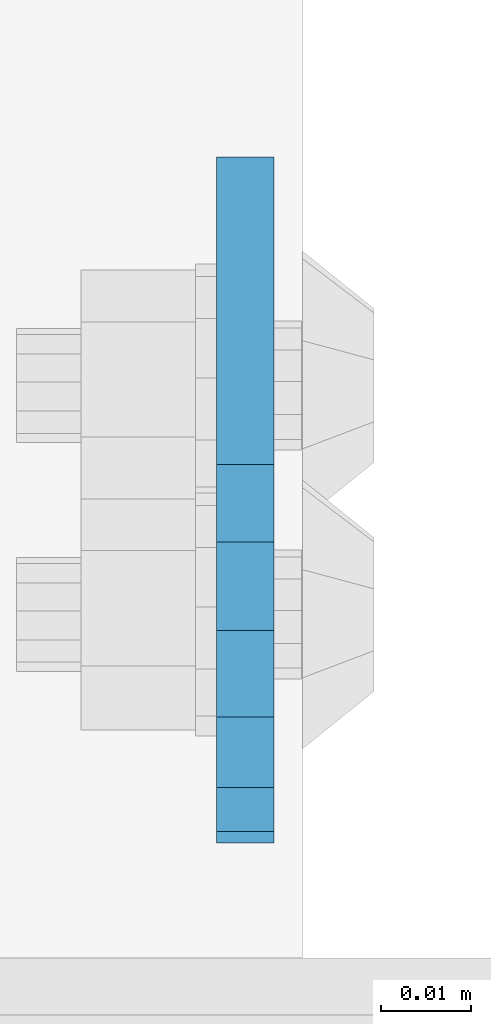
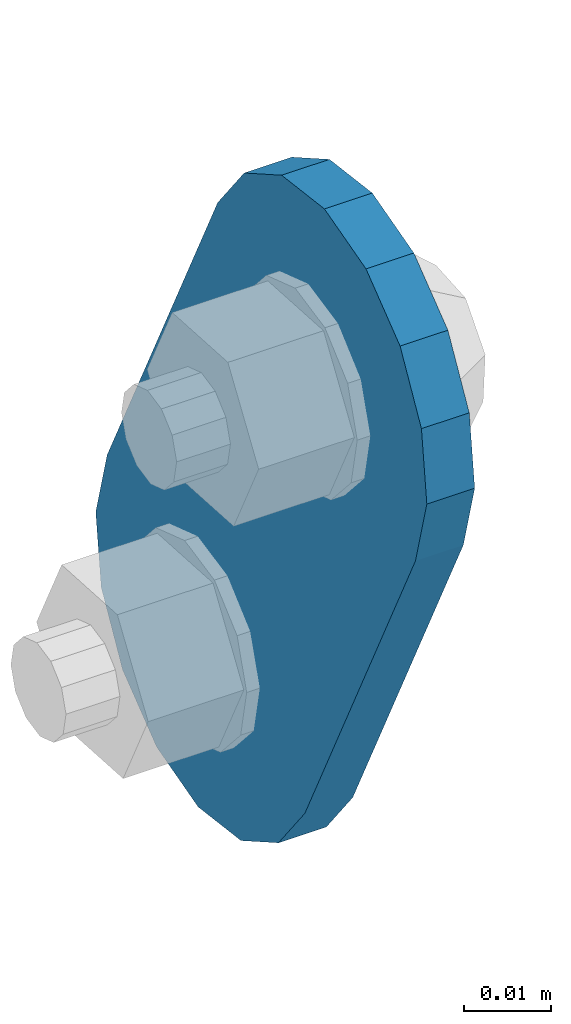
# One storey, part 1835 of 1876: 1 plate, 1 element without a shape of its own.
"""IFC2X3 building model written with IfcOpenShell, lengths in millimetres."""

from ifc_helpers import new_model, si_unit, frame, origin_with_axes, place, context, subcontext, project, spatial, faceted_brep, material, type_object, element, aggregate, save


model = new_model("IFC2X3")

# Units and contexts
model_context = context("Model", 3, precision=1e-05, world=origin_with_axes())
body_context = subcontext(model_context, "Body", "Model", "MODEL_VIEW")
ifc_project = project(units=[si_unit("LENGTHUNIT", "METRE", prefix="MILLI"), si_unit("AREAUNIT", "SQUARE_METRE"), si_unit("VOLUMEUNIT", "CUBIC_METRE"), si_unit("MASSUNIT", "GRAM", prefix="KILO"), si_unit("TIMEUNIT", "SECOND"), si_unit("PLANEANGLEUNIT", "RADIAN"), si_unit("SOLIDANGLEUNIT", "STERADIAN"), si_unit("THERMODYNAMICTEMPERATUREUNIT", "DEGREE_CELSIUS"), si_unit("LUMINOUSINTENSITYUNIT", "LUMEN")], contexts=[model_context])

# Site, building, storey
site_placement = place(None, origin_with_axes())
site = spatial("IfcSite", under=ifc_project, at=site_placement, CompositionType="ELEMENT")
building_placement = place(site_placement, origin_with_axes())
building = spatial("IfcBuilding", under=site, at=building_placement, Name="Undefined", CompositionType="ELEMENT")
storey_placement = place(building_placement, origin_with_axes())
storey = spatial("IfcBuildingStorey", under=building, at=storey_placement, Name="Undefined", CompositionType="ELEMENT", Elevation=0.0)

# Assembly, plate
assembly_placement = place(storey_placement, origin_with_axes())
assembly = element("IfcElementAssembly", 1, at=assembly_placement, inside=storey, Name="PLATE", AssemblyPlace="NOTDEFINED", PredefinedType="RIGID_FRAME")
ifc_material = material(Name="STEEL/A36")
plate_type = type_object("IfcPlateType", PredefinedType="NOTDEFINED")
plate_placement = place(assembly_placement, frame((7905.73879597858, 14070.2592249372, 7895.37767748094), z_axis=(0.0, -0.894427191199917, -0.447213595099956), x_axis=(0.0, 0.447213595099955, -0.894427191199917)))
plate = element("IfcPlate", 2, at=plate_placement, type_object=plate_type, material=ifc_material, Name="PLATE", context=body_context, shape_type="Brep", body=[
    faceted_brep([(-8.59611645864788e-07, -3.17499999999654, 25.3999987589127), (1.93345873884391, -3.17499999999382, 35.1201580589886), (1.93345873884391, 3.17500000000564, 35.1201580589886), (-8.59611645864788e-07, 3.17500000000382, 25.3999987589132), (7.43948648259902, -3.17499999999109, 43.3605112870105), (7.43948648259902, 3.17500000000928, 43.3605112870105), (15.6798395242777, -3.17499999998654, 48.8665393096448), (15.6798395242777, 3.17500000001382, 48.8665393096448), (25.3999987589095, -3.17499999998199, 50.7999992370592), (25.3999987589095, 3.17500000001837, 50.7999992370592), (82.196130752618, -3.17499999998381, 50.7999992370605), (82.196130752618, 3.17500000001655, 50.7999992370642), (91.9162897887145, -3.17499999997926, 48.8665393918873), (91.9162897887145, 3.1750000000211, 48.8665393918909), (100.156642725027, -3.17499999997472, 43.3605115909359), (100.156642725027, 3.17500000002565, 43.3605115909395), (105.662670525982, -3.17499999997108, 35.1201586546285), (105.662670525986, 3.17500000002929, 35.1201586546358), (107.596130371159, -3.17499999996744, 25.3999996185757), (107.596130371159, 3.17500000003292, 25.3999996185794), (105.662670525981, -3.17499999996471, 15.6798405824902), (105.662670525981, 3.17500000003565, 15.6798405824939), (100.156642725024, -3.17499999996471, 7.43948764618654), (100.156642725025, 3.17500000003565, 7.43948764619017), (91.9162897887127, -3.17499999996562, 1.93345984522784), (91.9162897887127, 3.17500000003474, 1.93345984523148), (82.196130752618, -3.17499999996835, 4.54747350886464e-11), (82.196130752618, 3.1750000000311, 4.91127138957381e-11), (25.399998758905, -3.17499999999018, -8.64019966684282e-12), (25.399998758905, 3.17500000001019, -8.64019966684282e-12), (15.679839921364, -3.17499999999382, 1.9334597629304), (15.679839921364, 3.17500000000655, 1.9334597629304), (7.43948709043525, -3.17499999999654, 7.43948734220839), (7.43948709043525, 3.17500000000382, 7.43948734220885), (1.93345923228208, -3.17499999999654, 15.6798399868012), (1.93345923228208, 3.17500000000291, 15.6798399868012)], [[[0, 1, 2, 3]], [[1, 4, 5, 2]], [[4, 6, 7, 5]], [[6, 8, 9, 7]], [[8, 10, 11, 9]], [[10, 12, 13, 11]], [[12, 14, 15, 13]], [[14, 16, 17, 15]], [[16, 18, 19, 17]], [[18, 20, 21, 19]], [[20, 22, 23, 21]], [[22, 24, 25, 23]], [[24, 26, 27, 25]], [[26, 28, 29, 27]], [[28, 30, 31, 29]], [[30, 32, 33, 31]], [[32, 34, 35, 33]], [[34, 0, 3, 35]], [[5, 7, 9, 11, 13, 15, 17, 19, 21, 23, 25, 27, 29, 31, 33, 35, 3, 2]], [[34, 32, 30, 28, 26, 24, 22, 20, 18, 16, 14, 12, 10, 8, 6, 4, 1, 0]]]),
])
aggregate(assembly, [plate])

save(model, "model.ifc")
